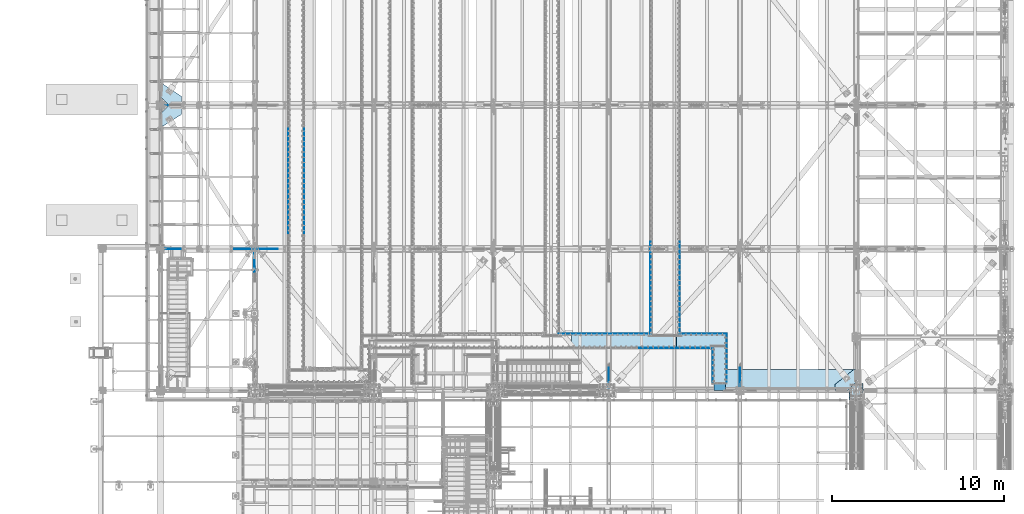
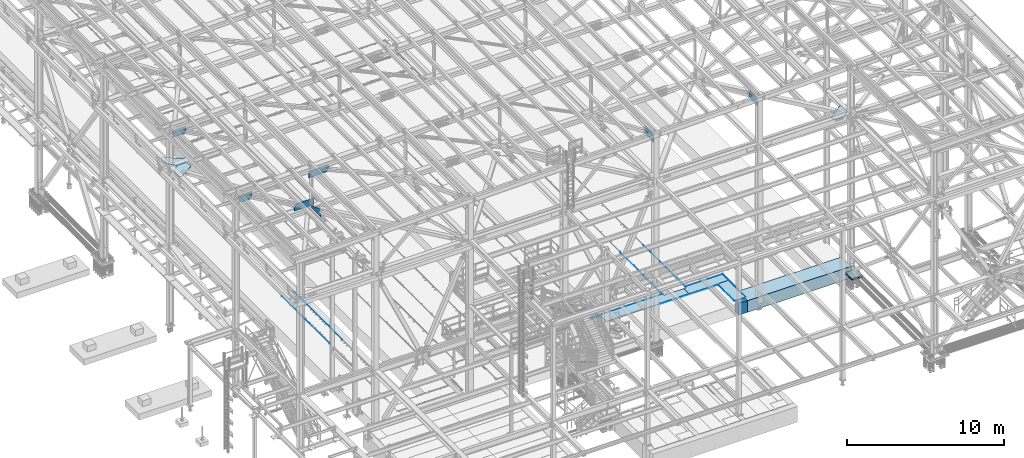
# One storey, part 2976 of 3843: 24 plates, 2 slabs, 24 elements without a shape of their own.
"""IFC2X3 building model written with IfcOpenShell, lengths in millimetres."""

from ifc_helpers import new_model, si_unit, frame, origin_with_axes, place, context, subcontext, project, spatial, faceted_brep, material, type_object, element, aggregate, save


model = new_model("IFC2X3")

# Units and contexts
model_context = context("Model", 3, precision=1e-05, world=origin_with_axes())
body_context = subcontext(model_context, "Body", "Model", "MODEL_VIEW")
ifc_project = project(units=[si_unit("LENGTHUNIT", "METRE", prefix="MILLI"), si_unit("AREAUNIT", "SQUARE_METRE"), si_unit("VOLUMEUNIT", "CUBIC_METRE"), si_unit("MASSUNIT", "GRAM", prefix="KILO"), si_unit("TIMEUNIT", "SECOND"), si_unit("PLANEANGLEUNIT", "RADIAN"), si_unit("SOLIDANGLEUNIT", "STERADIAN"), si_unit("THERMODYNAMICTEMPERATUREUNIT", "DEGREE_CELSIUS"), si_unit("LUMINOUSINTENSITYUNIT", "LUMEN")], contexts=[model_context])

# Site, building, storey
site_placement = place(None, origin_with_axes())
site = spatial("IfcSite", under=ifc_project, at=site_placement, CompositionType="ELEMENT")
building_placement = place(site_placement, origin_with_axes())
building = spatial("IfcBuilding", under=site, at=building_placement, Name="Undefined", CompositionType="ELEMENT")
storey_placement = place(building_placement, origin_with_axes())
storey = spatial("IfcBuildingStorey", under=building, at=storey_placement, Name="Undefined", CompositionType="ELEMENT", Elevation=0.0)

# Assembly, plate
assembly_1_placement = place(storey_placement, origin_with_axes())
assembly_1 = element("IfcElementAssembly", 1, at=assembly_1_placement, inside=storey, Name="EMBED_ANGLE", AssemblyPlace="NOTDEFINED", PredefinedType="RIGID_FRAME")
ifc_material_1 = material(Name="STEEL/A36")
plate_type_1 = type_object("IfcPlateType", PredefinedType="NOTDEFINED")
plate_1_placement = place(assembly_1_placement, frame((65069.2755560959, 28911.5502021554, 30480.0000003815), z_axis=(-1.0, 0.0, 0.0), x_axis=(0.0, 0.0, -1.0)))
plate_1 = element("IfcPlate", 2, at=plate_1_placement, type_object=plate_type_1, material=ifc_material_1, Name="PLATE", context=body_context, shape_type="Brep", body=[
    faceted_brep([(3.80565325031057e-07, -6.34999999414867, 5327.71371118224), (20.6374995432707, -6.34999999414867, 5327.71371118224), (25.3999996185303, -1.58765204696101, 5332.47605989833), (25.3999996185303, 6.3500000058666, 5340.41355616353), (3.81471181754023e-07, 6.3500000058666, 5340.41355616181), (25.3999996185303, -1.58750828453412, 7.93771022401779), (25.3999999999942, 6.34999999994034, 2.91038304567337e-11), (7.27595761418343e-12, 6.3499999046162, 0.0), (9.05856722965837e-10, -6.34999999998763, 12.7002012917728), (20.6374995432707, -6.34999999998763, 12.7002012917728)], [[[0, 1, 2, 3, 4]], [[3, 2, 5, 6]], [[4, 3, 6, 7]], [[0, 4, 7, 8]], [[1, 0, 8, 9]], [[2, 1, 9, 5]], [[8, 7, 6, 5, 9]]]),
])
aggregate(assembly_1, [plate_1])

assembly_2_placement = place(storey_placement, origin_with_axes())
assembly_2 = element("IfcElementAssembly", 3, at=assembly_2_placement, inside=storey, Name="EMBED_ANGLE", AssemblyPlace="NOTDEFINED", PredefinedType="RIGID_FRAME")
plate_2_placement = place(assembly_2_placement, frame((69501.5118787198, 28911.518202002, 30480.0), z_axis=(-0.999999999941156, 1.08469999968456e-05, -1.75999998152391e-07), x_axis=(0.0, 0.0, -1.0)))
plate_2 = element("IfcPlate", 4, at=plate_2_placement, type_object=plate_type_1, material=ifc_material_1, Name="PLATE", context=body_context, shape_type="Brep", body=[
    faceted_brep([(0.0, -6.34999999832871, 2743.20009635536), (20.6374992370511, -6.34999999832871, 2743.20009635536), (25.3999994290425, -1.58757329854052, 2747.96241314906), (25.3999992370591, 6.35000000169384, 2755.89995210941), (0.0, 6.35000000169384, 2755.89995210769), (25.3999996167695, 6.35000000001673, 12.718919349456), (0.0, 6.35000000001673, 12.718919349456), (0.0, -6.3499999046162, 0.0), (20.6375000381231, -6.35000000004948, 2.5465851649642e-11), (25.3999996182029, -1.61924383396763, 4.73780372471083)], [[[0, 1, 2, 3, 4]], [[4, 3, 5, 6]], [[0, 4, 6, 7]], [[1, 0, 7, 8]], [[2, 1, 8, 9]], [[3, 2, 9, 5]], [[8, 7, 6, 5, 9]]]),
])
aggregate(assembly_2, [plate_2])

assembly_3_placement = place(storey_placement, origin_with_axes())
assembly_3 = element("IfcElementAssembly", 5, at=assembly_3_placement, inside=storey, Name="EMBED_ANGLE", AssemblyPlace="NOTDEFINED", PredefinedType="RIGID_FRAME")
plate_3_placement = place(assembly_3_placement, frame((69495.1619228334, 26000.0750029394, 30480.0000003815), z_axis=(0.0, 1.0, 0.0), x_axis=(0.0, 0.0, -1.0)))
plate_3 = element("IfcPlate", 6, at=plate_3_placement, type_object=plate_type_1, material=ifc_material_1, Name="PLATE", context=body_context, shape_type="Brep", body=[
    faceted_brep([(20.6375000381231, -6.35000000004948, 2.5465851649642e-11), (0.0, -6.3499999046162, 0.0), (0.0, 6.34999999999854, 12.6999998092651), (25.3999996185303, 6.34999999999854, 12.6999999977998), (25.3999996185303, -1.58769240400579, 4.77717201472478), (25.3999996185303, -1.58766331075458, 2913.04279886661), (20.6374996185295, -6.34999999172578, 2917.8249962469), (3.81471181754023e-07, -6.34999999172578, 2917.82499624551), (3.79812263417989e-07, 6.3500000082422, 2905.12503064128), (25.3999996185303, 6.3500000082422, 2905.12503064128)], [[[0, 1, 2, 3, 4]], [[0, 4, 5, 6]], [[1, 0, 6, 7]], [[2, 1, 7, 8]], [[3, 2, 8, 9]], [[4, 3, 9, 5]], [[8, 7, 6, 5, 9]]]),
])
aggregate(assembly_3, [plate_3])

assembly_4_placement = place(storey_placement, origin_with_axes())
assembly_4 = element("IfcElementAssembly", 7, at=assembly_4_placement, inside=storey, Name="EMBED_ANGLE", AssemblyPlace="NOTDEFINED", PredefinedType="RIGID_FRAME")
plate_4_placement = place(assembly_4_placement, frame((68669.6619595486, 26000.0749946097, 30480.0000003815), z_axis=(0.0, 1.0, 0.0), x_axis=(0.0, 0.0, -1.0)))
plate_4 = element("IfcPlate", 8, at=plate_4_placement, type_object=plate_type_1, material=ifc_material_1, Name="PLATE", context=body_context, shape_type="Brep", body=[
    faceted_brep([(20.6374996185295, 6.34999999747379, 2079.6250003181), (3.79157427232713e-07, 6.34999999747379, 2079.6250003181), (3.81471181754023e-07, -6.35000000253785, 2092.32499955647), (25.3999996185303, -6.35000000253785, 2092.32499955819), (25.3999996185303, 1.5874999971129, 2084.38750129905), (25.3999996185303, -6.34999999999854, 12.7000000000044), (25.399999618523, 1.58750000001601, 4.76249999998981), (20.6374996185295, 6.35000000000218, -7.27595761418343e-12), (7.27595761418343e-12, 6.3499999046162, 0.0), (0.0, -6.34999999999854, 12.6999998092651)], [[[0, 1, 2, 3, 4]], [[4, 3, 5, 6]], [[0, 4, 6, 7]], [[1, 0, 7, 8]], [[2, 1, 8, 9]], [[3, 2, 9, 5]], [[8, 7, 6, 5, 9]]]),
])
aggregate(assembly_4, [plate_4])

assembly_5_placement = place(storey_placement, origin_with_axes())
assembly_5 = element("IfcElementAssembly", 9, at=assembly_5_placement, inside=storey, Name="EMBED_ANGLE", AssemblyPlace="NOTDEFINED", PredefinedType="RIGID_FRAME")
plate_5_placement = place(assembly_5_placement, frame((64415.1623417777, 28086.05, 30480.0000003815), z_axis=(1.0, 0.0, 0.0), x_axis=(0.0, 0.0, -1.0)))
plate_5 = element("IfcPlate", 10, at=plate_5_placement, type_object=plate_type_1, material=ifc_material_1, Name="PLATE", context=body_context, shape_type="Brep", body=[
    faceted_brep([(0.0, -6.3499999046162, 0.0), (7.27595761418343e-12, 6.3499999046162, 0.0), (25.3999999999942, 6.34999999994034, 2.91038304567337e-11), (25.3999996185921, -1.5874999999869, 7.27595761418343e-11), (20.6375000381231, -6.35000000004948, 2.5465851649642e-11), (25.3999995817285, 6.35000000567379, 4260.84946592642), (25.4000003800502, -1.58748479768838, 4252.91198546833), (20.6374996185295, -6.34999999434149, 4248.14946486166), (3.43643478117883e-07, -6.34999999434149, 4248.14946486166), (3.44669388141483e-07, 6.35000000567379, 4260.8494659247)], [[[0, 1, 2, 3, 4]], [[3, 2, 5, 6]], [[4, 3, 6, 7]], [[0, 4, 7, 8]], [[1, 0, 8, 9]], [[2, 1, 9, 5]], [[8, 7, 6, 5, 9]]]),
])
aggregate(assembly_5, [plate_5])

assembly_6_placement = place(storey_placement, origin_with_axes())
assembly_6 = element("IfcElementAssembly", 11, at=assembly_6_placement, inside=storey, Name="EMBED_ANGLE", AssemblyPlace="NOTDEFINED", PredefinedType="RIGID_FRAME")
plate_6_placement = place(assembly_6_placement, frame((66751.962, 34264.6001953125, 30479.9999992371), z_axis=(0.0, -1.0, 0.0), x_axis=(0.0, 0.0, -1.0)))
plate_6 = element("IfcPlate", 12, at=plate_6_placement, type_object=plate_type_1, material=ifc_material_1, Name="PLATE", context=body_context, shape_type="Brep", body=[
    faceted_brep([(25.3999996185303, -6.34999999999491, 2.91038304567337e-11), (0.0, -6.3499999046162, 0.0), (7.27595761418343e-12, 6.3499999046162, 0.0), (20.6374996185295, 6.35000000000218, -7.27595761418343e-12), (25.3999996185921, 1.58750000000146, 7.27595761418343e-11), (25.3999996185303, -6.35000000000582, 5359.40029227788), (3.81471181754023e-07, -6.35000000000582, 5359.40029227788), (3.80568963009864e-07, 6.35000000000582, 5346.70019531149), (20.6374984696922, 6.35000000000582, 5346.70019531149), (25.3999995800368, 1.58750000000873, 5351.46269531147)], [[[0, 1, 2, 3, 4]], [[1, 0, 5, 6]], [[2, 1, 6, 7]], [[3, 2, 7, 8]], [[4, 3, 8, 9]], [[0, 4, 9, 5]], [[8, 7, 6, 5, 9]]]),
])
aggregate(assembly_6, [plate_6])

assembly_7_placement = place(storey_placement, origin_with_axes())
assembly_7 = element("IfcElementAssembly", 13, at=assembly_7_placement, inside=storey, Name="EMBED_ANGLE", AssemblyPlace="NOTDEFINED", PredefinedType="RIGID_FRAME")
plate_7_placement = place(assembly_7_placement, frame((65062.9255556641, 34264.6002929687, 30479.9999992371), z_axis=(0.0, -1.0, 0.0), x_axis=(0.0, 0.0, -1.0)))
plate_7 = element("IfcPlate", 14, at=plate_7_placement, type_object=plate_type_1, material=ifc_material_1, Name="PLATE", context=body_context, shape_type="Brep", body=[
    faceted_brep([(0.0, -6.3499999046162, 0.0), (7.27595761418343e-12, 6.3499999046162, 0.0), (25.3999999999942, 6.34999999994034, 2.91038304567337e-11), (25.3999996185921, -1.5874999999869, 7.27595761418343e-11), (20.6375000381231, -6.35000000004948, 2.5465851649642e-11), (25.3999996185303, 6.34999999999854, 5359.40009081333), (25.3999996185303, -1.58750000000146, 5351.46279296873), (20.6374984696922, -6.34999999999854, 5346.70029296873), (3.80568963009864e-07, -6.34999999999854, 5346.70029296873), (3.81471181754023e-07, 6.34999999999854, 5359.40009081333)], [[[0, 1, 2, 3, 4]], [[3, 2, 5, 6]], [[4, 3, 6, 7]], [[0, 4, 7, 8]], [[1, 0, 8, 9]], [[2, 1, 9, 5]], [[8, 7, 6, 5, 9]]]),
])
aggregate(assembly_7, [plate_7])

assembly_8_placement = place(storey_placement, origin_with_axes())
assembly_8 = element("IfcElementAssembly", 15, at=assembly_8_placement, inside=storey, Name="PLATE", AssemblyPlace="NOTDEFINED", PredefinedType="RIGID_FRAME")
ifc_material_2 = material(Name="STEEL/A572-50")
plate_type_2 = type_object("IfcPlateType", PredefinedType="NOTDEFINED")
plate_8_placement = place(assembly_8_placement, frame((69482.4619438142, 28098.7500050658, 30467.3), z_axis=(-1.0, 0.0, 0.0), x_axis=(0.0, 1.0, 0.0)))
plate_8 = element("IfcPlate", 16, at=plate_8_placement, type_object=plate_type_2, material=ifc_material_2, Name="PLATE", context=body_context, shape_type="Brep", body=[
    faceted_brep([(704.849965960948, -12.7000000000007, 2911.47703445752), (704.84996764666, -12.7000000000007, 2742.90588481282), (704.84996764666, 12.7000000000007, 2742.90588481282), (704.849965960948, 12.7000000000007, 2911.47703445752), (800.073910520936, -12.7000000000007, 2742.90588576545), (800.073910520936, 12.7000000000007, 2742.90588576545), (-3.91444700653665e-06, -12.7000000000007, 2911.47701656907), (-3.91444700653665e-06, 12.7000000000007, 2911.47701656907), (-1.07959931483492e-06, 12.7000000000007, 802.981070808615), (-1.07959931483492e-06, -12.7000000000007, 802.981070808615), (85.724977552105, 12.7000000000007, 802.981070808499), (85.724977552105, -12.7000000000007, 802.981070808499), (85.724990093946, 12.7000000000007, 2.3283064365387e-10), (85.724990093946, -12.7000000000007, 2.3283064365387e-10), (800.094554221527, 12.7000000000007, 2.2846506908536e-09), (800.094554221527, -12.7000000000007, 2.2846506908536e-09)], [[[0, 1, 2, 3]], [[4, 5, 2, 1]], [[6, 7, 8, 9]], [[9, 8, 10, 11]], [[11, 10, 12, 13]], [[14, 15, 13, 12]], [[0, 6, 9, 11, 13, 15, 4, 1]], [[7, 6, 0, 3]], [[14, 12, 10, 8, 7, 3, 2, 5]], [[15, 14, 5, 4]]]),
])
aggregate(assembly_8, [plate_8])

assembly_9_placement = place(storey_placement, origin_with_axes())
assembly_9 = element("IfcElementAssembly", 17, at=assembly_9_placement, inside=storey, Name="PLATE", AssemblyPlace="NOTDEFINED", PredefinedType="RIGID_FRAME")
plate_9_placement = place(assembly_9_placement, frame((66567.8099273582, 28098.7500302273, 30467.3), z_axis=(-1.0, 0.0, 0.0), x_axis=(0.0, 1.0, 0.0)))
plate_9 = element("IfcPlate", 18, at=plate_9_placement, type_object=plate_type_2, material=ifc_material_2, Name="PLATE", context=body_context, shape_type="Brep", body=[
    faceted_brep([(704.849969829345, -12.7000000000007, 1.23691279441118e-09), (704.849969829345, 12.7000000000007, 1.23691279441118e-09), (704.850077272724, 12.7000000000007, 1492.1843209475), (704.850077272724, -12.7000000000007, 1492.1843209475), (800.116650633714, -12.7000000000007, 1492.18431408831), (800.116650633714, 12.7000000000007, 1492.18431408832), (0.0, -12.6999999999971, 0.0), (0.000493600375193637, -12.7000000000007, 6095.99999979503), (0.000493600375193637, 12.7000000000007, 6095.99999979503), (0.0, 12.6999999999971, 0.0), (800.116981974414, -12.7000000000007, 6096.00000000144), (800.116981974414, 12.7000000000007, 6096.00000000144)], [[[0, 1, 2, 3]], [[4, 3, 2, 5]], [[6, 7, 8, 9]], [[7, 10, 11, 8]], [[11, 10, 4, 5]], [[1, 9, 8, 11, 5, 2]], [[6, 9, 1, 0]], [[10, 7, 6, 0, 3, 4]]]),
])
aggregate(assembly_9, [plate_9])

assembly_10_placement = place(storey_placement, origin_with_axes())
assembly_10 = element("IfcElementAssembly", 19, at=assembly_10_placement, inside=storey, Name="PLATE", AssemblyPlace="NOTDEFINED", PredefinedType="RIGID_FRAME")
plate_10_placement = place(assembly_10_placement, frame((68682.3618078103, 28181.2999906114, 30467.3), z_axis=(1.0, 0.0, 0.0), x_axis=(0.0, -1.0, 0.0)))
plate_10 = element("IfcPlate", 20, at=plate_10_placement, type_object=plate_type_2, material=ifc_material_2, Name="PLATE", context=body_context, shape_type="Brep", body=[
    faceted_brep([(0.0, -12.6999999999971, 0.0), (5.08003176946659e-05, -12.7000000000007, 800.100116695074), (5.08003176946659e-05, 12.7000000000007, 800.100116695074), (0.0, 12.6999999999971, 0.0), (2162.26889035886, -12.7000000000007, 800.099943196918), (2162.26889035886, 12.7000000000007, 800.099943196918), (2162.17500086908, -12.7000000000007, -6.18456397205591e-09), (2162.17500086908, 12.7000000000007, -6.18456397205591e-09)], [[[0, 1, 2, 3]], [[1, 4, 5, 2]], [[4, 6, 7, 5]], [[6, 0, 3, 7]], [[5, 7, 3, 2]], [[6, 4, 1, 0]]]),
])
aggregate(assembly_10, [plate_10])

assembly_11_placement = place(storey_placement, origin_with_axes())
assembly_11 = element("IfcElementAssembly", 21, at=assembly_11_placement, inside=storey, Name="BEAM", AssemblyPlace="NOTDEFINED", PredefinedType="RIGID_FRAME")
plate_type_3 = type_object("IfcPlateType", PredefinedType="NOTDEFINED")
plate_11_placement = place(assembly_11_placement, frame((42265.3420523382, 33845.4999999999, 42433.4469214496), z_axis=(-0.00048281500021403, 0.0, 0.999999883444831), x_axis=(-0.999999883445314, 0.0, -0.000482814000210543)))
plate_11 = element("IfcPlate", 22, at=plate_11_placement, type_object=plate_type_3, material=ifc_material_2, Name="PLATE", context=body_context, shape_type="Brep", body=[
    faceted_brep([(0.0, -9.52500000000146, 0.0), (-1.35332811623812e-09, -9.52500000000146, 528.488950446263), (-1.35332811623812e-09, 9.52500000000146, 528.488950446263), (0.0, 9.52500000000146, 0.0), (1251.68139171164, -9.52500000000146, 529.093281072412), (1251.68139171164, 9.52500000000146, 529.093281072412), (1397.00000000605, -9.52500000000146, 261.165040183223), (1397.00000000605, 9.52500000000146, 261.165040183223), (1397.00000000671, -9.52500000000146, 3.5579432733357e-09), (1397.00000000671, 9.52500000000146, 3.5579432733357e-09)], [[[0, 1, 2, 3]], [[1, 4, 5, 2]], [[4, 6, 7, 5]], [[6, 8, 9, 7]], [[8, 0, 3, 9]], [[5, 7, 9, 3, 2]], [[8, 6, 4, 1, 0]]]),
])

assembly_12_placement = place(storey_placement, origin_with_axes())
assembly_12 = element("IfcElementAssembly", 23, at=assembly_12_placement, inside=storey, Name="EMBED_ANGLE", AssemblyPlace="NOTDEFINED", PredefinedType="RIGID_FRAME")
plate_type_4 = type_object("IfcPlateType", PredefinedType="NOTDEFINED")
plate_12_placement = place(assembly_12_placement, frame((44925.9959999999, 40846.3749999999, 30479.9999973298), z_axis=(0.0, -1.0, 0.0), x_axis=(0.0, 0.0, -1.0)))
plate_12 = element("IfcPlate", 24, at=plate_12_placement, type_object=plate_type_4, material=ifc_material_1, Name="PLATE", context=body_context, shape_type="Brep", body=[
    faceted_brep([(15.875, 1.58750000000146, 6096.0), (15.875, 1.58749999204883, -3.63797880709171e-12), (11.1125018504281, 6.35000000000582, -7.27595761418343e-12), (11.1124996186481, 6.34999999999854, 6096.0), (0.0, -6.3499999046162, 0.0), (3.81471181754023e-07, -6.34999999999854, 6096.0), (3.81471181754023e-07, 6.34999999999854, 6096.0), (7.27595761418343e-12, 6.3499999046162, 0.0), (15.875, -6.35000000000582, 3.63797880709171e-12), (15.875, -6.34999999999854, 6096.0)], [[[0, 1, 2, 3]], [[4, 5, 6, 7]], [[8, 9, 5, 4]], [[6, 5, 9, 0, 3]], [[7, 6, 3, 2]], [[8, 4, 7, 2, 1]], [[9, 8, 1, 0]]]),
])
aggregate(assembly_12, [plate_12])

assembly_13_placement = place(storey_placement, origin_with_axes())
assembly_13 = element("IfcElementAssembly", 25, at=assembly_13_placement, inside=storey, Name="EMBED_ANGLE", AssemblyPlace="NOTDEFINED", PredefinedType="RIGID_FRAME")
plate_13_placement = place(assembly_13_placement, frame((43998.896, 40846.3749999999, 30479.9999977112), z_axis=(0.0, -1.0, 0.0), x_axis=(0.0, 0.0, -1.0)))
plate_13 = element("IfcPlate", 26, at=plate_13_placement, type_object=plate_type_4, material=ifc_material_1, Name="PLATE", context=body_context, shape_type="Brep", body=[
    faceted_brep([(15.8749946755343, -1.58750000000146, 6096.0), (11.1124999999702, -6.34999999999854, 6096.0), (11.1125001907349, -6.35000000006371, 0.0), (15.875, -1.58750000024156, -3.63797880709171e-12), (0.0, -6.3499999046162, 0.0), (3.81471181754023e-07, -6.34999999999854, 6096.0), (3.81471181754023e-07, 6.34999999999854, 6096.0), (7.27595761418343e-12, 6.3499999046162, 0.0), (15.875, 6.34999999999854, 6096.0), (15.875, 6.34999999999854, -3.63797880709171e-12)], [[[0, 1, 2, 3]], [[4, 5, 6, 7]], [[8, 9, 7, 6]], [[9, 8, 0, 3]], [[4, 7, 9, 3, 2]], [[5, 4, 2, 1]], [[8, 6, 5, 1, 0]]]),
])
aggregate(assembly_13, [plate_13])

assembly_14_placement = place(storey_placement, origin_with_axes())
assembly_14 = element("IfcElementAssembly", 27, at=assembly_14_placement, inside=storey, Name="PLATE", AssemblyPlace="NOTDEFINED", PredefinedType="RIGID_FRAME")
plate_type_5 = type_object("IfcPlateType", PredefinedType="NOTDEFINED")
plate_14_placement = place(assembly_14_placement, frame((36582.3499999983, 41719.5, 42232.2630004883), z_axis=(1.0, 0.0, 0.0), x_axis=(0.0, -1.0, 0.0)))
plate_14 = element("IfcPlate", 28, at=plate_14_placement, type_object=plate_type_5, material=ifc_material_2, Name="PLATE", context=body_context, shape_type="Brep", body=[
    faceted_brep([(0.0, -14.2874999999985, 0.0), (-475.45624995463, -14.2874999999985, 476.25000003165), (-475.45624995463, 14.2874999999985, 476.25000003165), (0.0, 14.2874999999985, 0.0), (-475.45624994392, -14.2874999999985, 1212.85000003893), (-475.45624994392, 14.2874999999985, 1212.85000003893), (60.9233280424742, -14.2874999999985, 1212.85000000017), (60.9233280424742, 14.2874999999985, 1212.85000000017), (736.600000000006, -14.2874999999985, 149.225000001694), (736.600000000006, 14.2874999999985, 149.225000001694), (736.599999940488, -14.2874999999985, 0.0), (736.599999940488, 14.2874999999985, 0.0)], [[[0, 1, 2, 3]], [[1, 4, 5, 2]], [[4, 6, 7, 5]], [[6, 8, 9, 7]], [[8, 10, 11, 9]], [[10, 0, 3, 11]], [[5, 7, 9, 11, 3, 2]], [[10, 8, 6, 4, 1, 0]]]),
])
aggregate(assembly_14, [plate_14])

assembly_15_placement = place(storey_placement, origin_with_axes())
assembly_15 = element("IfcElementAssembly", 29, at=assembly_15_placement, inside=storey, Name="PLATE", AssemblyPlace="NOTDEFINED", PredefinedType="RIGID_FRAME")
plate_15_placement = place(assembly_15_placement, frame((37058.6, 42209.2437500015, 42232.2630004887), z_axis=(0.0, 1.0, 0.0), x_axis=(1.0, 0.0, 0.0)))
plate_15 = element("IfcPlate", 30, at=plate_15_placement, type_object=plate_type_5, material=ifc_material_2, Name="PLATE", context=body_context, shape_type="Brep", body=[
    faceted_brep([(0.0, -14.2874999999985, 0.0), (-476.249999993554, -14.2874999999985, 475.456250073548), (-476.249999993554, 14.2874999999985, 475.456250073548), (0.0, 14.2874999999985, 0.0), (-476.249999993568, -14.2874999999985, 1212.05625003844), (-476.249999993568, 14.2874999999985, 1212.05625003844), (-327.025000000001, -14.2874999999985, 1212.05624999852), (-327.025000000001, 14.2874999999985, 1212.05624999852), (736.599999997103, -14.2874999999985, 513.749258709016), (736.599999997103, 14.2874999999985, 513.749258709016), (736.599999940488, -14.2874999999985, 0.0), (736.599999940488, 14.2874999999985, 0.0)], [[[0, 1, 2, 3]], [[1, 4, 5, 2]], [[4, 6, 7, 5]], [[6, 8, 9, 7]], [[8, 10, 11, 9]], [[10, 0, 3, 11]], [[5, 7, 9, 11, 3, 2]], [[10, 8, 6, 4, 1, 0]]]),
])
aggregate(assembly_15, [plate_15])

assembly_16_placement = place(storey_placement, origin_with_axes())
assembly_16 = element("IfcElementAssembly", 31, at=assembly_16_placement, inside=storey, Name="PLATE", AssemblyPlace="NOTDEFINED", PredefinedType="RIGID_FRAME")
plate_16_placement = place(assembly_16_placement, frame((77008.0374999847, 26098.5000000001, 42232.2630004883), z_axis=(-1.0, 0.0, 0.0), x_axis=(0.0, 1.0, 0.0)))
plate_16 = element("IfcPlate", 32, at=plate_16_placement, type_object=plate_type_5, material=ifc_material_2, Name="PLATE", context=body_context, shape_type="Brep", body=[
    faceted_brep([(0.0, -14.2874999999985, 0.0), (-476.250000048109, -14.2874999999985, 477.83749997773), (-476.250000048109, 14.2874999999985, 477.83749997773), (0.0, 14.2874999999985, 0.0), (-476.250000048109, -14.2874999999985, 1214.43749997662), (-476.250000048109, 14.2874999999985, 1214.43749997662), (-116.181480294774, -14.2874999999985, 1214.4374999766), (-116.181480294774, 14.2874999999985, 1214.4374999766), (736.600000090519, -14.2874999999985, 147.637499993114), (736.600000090519, 14.2874999999985, 147.637499993114), (736.599999940488, -14.2874999999985, 0.0), (736.599999940488, 14.2874999999985, 0.0)], [[[0, 1, 2, 3]], [[1, 4, 5, 2]], [[4, 6, 7, 5]], [[6, 8, 9, 7]], [[8, 10, 11, 9]], [[10, 0, 3, 11]], [[5, 7, 9, 11, 3, 2]], [[10, 8, 6, 4, 1, 0]]]),
])
aggregate(assembly_16, [plate_16])

# Plate
plate_type_6 = type_object("IfcPlateType", PredefinedType="NOTDEFINED")
plate_17_placement = place(assembly_11_placement, frame((42038.5875000002, 32495.5135896303, 42405.9268950663), z_axis=(0.0, -0.000321877000067616, 0.999999948197597), x_axis=(0.0, 0.999999948197597, 0.000321877000061539)))
plate_17 = element("IfcPlate", 33, at=plate_17_placement, type_object=plate_type_6, material=ifc_material_2, context=body_context, shape_type="Brep", body=[
    faceted_brep([(0.0, -7.9375, 0.0), (2.18278728425503e-11, -7.9375, 73.9483431657936), (2.18278728425503e-11, 7.9375, 73.9483431657936), (0.0, 7.9375, 0.0), (178.772091322528, -7.9375, 549.452853513401), (178.772091322528, 7.9375, 549.452853513401), (1136.46773030707, -7.9375, 177.799999998424), (1136.46773030707, 7.9375, 177.799999998424), (1136.46773030702, -7.9375, -2.83762346953154e-10), (1136.46773030702, 7.9375, -2.83762346953154e-10)], [[[0, 1, 2, 3]], [[1, 4, 5, 2]], [[4, 6, 7, 5]], [[6, 8, 9, 7]], [[8, 0, 3, 9]], [[5, 7, 9, 3, 2]], [[8, 6, 4, 1, 0]]]),
])

aggregate(assembly_11, [plate_11, plate_17])

# Assembly, plate
assembly_17_placement = place(storey_placement, origin_with_axes())
assembly_17 = element("IfcElementAssembly", 34, at=assembly_17_placement, inside=storey, Name="BEAM", AssemblyPlace="NOTDEFINED", PredefinedType="RIGID_FRAME")
plate_type_7 = type_object("IfcPlateType", PredefinedType="NOTDEFINED")
plate_18_placement = place(assembly_17_placement, frame((36772.8500000198, 33845.5, 45028.8425329179), z_axis=(1.0, 0.0, 0.0), x_axis=(0.0, 0.0, -1.0)))
plate_18 = element("IfcPlate", 35, at=plate_18_placement, type_object=plate_type_7, material=ifc_material_2, Name="PLATE", context=body_context, shape_type="Brep", body=[
    faceted_brep([(1.0415270375961, -9.52500000000146, 979.158504298284), (-18.0040135895688, 9.52500000000146, 978.746371852198), (3.17538710204826, 9.52500000000146, 0.0), (22.2298459928788, -9.52500000000146, 0.0), (274.347507502687, -9.52500000000146, 985.072658402103), (274.347507502687, 9.52500000000146, 985.072658402103), (520.012681549633, -9.52500000000146, 851.982529440364), (520.012681549633, 9.52500000000146, 851.982529440364), (520.012681549633, -9.52500000000146, 0.0), (520.012681549633, 9.52500000000146, 0.0)], [[[0, 1, 2, 3]], [[4, 5, 1, 0]], [[4, 6, 7, 5]], [[6, 8, 9, 7]], [[9, 8, 3, 2]], [[5, 7, 9, 2, 1]], [[8, 6, 4, 0, 3]]]),
])

assembly_18_placement = place(storey_placement, origin_with_axes())
assembly_18 = element("IfcElementAssembly", 36, at=assembly_18_placement, inside=storey, Name="BEAM", AssemblyPlace="NOTDEFINED", PredefinedType="RIGID_FRAME")
plate_type_8 = type_object("IfcPlateType", PredefinedType="NOTDEFINED")
plate_19_placement = place(assembly_18_placement, frame((36772.8499999893, 42202.1, 45030.1542954677), z_axis=(1.0, 0.0, 0.0), x_axis=(0.0, 0.0, -1.0)))
plate_19 = element("IfcPlate", 37, at=plate_19_placement, type_object=plate_type_8, material=ifc_material_2, Name="PLATE", context=body_context, shape_type="Brep", body=[
    faceted_brep([(22.2326984329993, 9.52500000000146, 0.0), (3.17609494728822, -9.52499999999418, 0.0), (-22.2467702547365, -9.52500000000146, 964.427693481834), (-3.20338629249454, 9.52500000000146, 964.929687703894), (293.085216323067, -9.52500000000146, 972.740020514007), (293.085216323067, 9.52500000000146, 972.740020514007), (516.815926009396, -9.52500000000146, 852.487909349147), (516.815926009396, 9.52500000000146, 852.487909349147), (516.815926009396, -9.52500000000146, 0.0), (516.815926009396, 9.52500000000146, 0.0)], [[[0, 1, 2, 3]], [[4, 5, 3, 2]], [[4, 6, 7, 5]], [[6, 8, 9, 7]], [[9, 8, 1, 0]], [[5, 7, 9, 0, 3]], [[8, 6, 4, 2, 1]]]),
])
aggregate(assembly_18, [plate_19])

# Plate
plate_type_9 = type_object("IfcPlateType", PredefinedType="NOTDEFINED")
plate_20_placement = place(assembly_17_placement, frame((43373.6092947943, 33845.5, 45171.6784401758), z_axis=(0.0216342480057937, 0.0, -0.999765952267441), x_axis=(-0.999765952267441, 0.0, -0.0216342480057875)))
plate_20 = element("IfcPlate", 38, at=plate_20_placement, type_object=plate_type_9, material=ifc_material_2, Name="PLATE", context=body_context, shape_type="Brep", body=[
    faceted_brep([(0.0, -9.52500000000146, 0.0), (-3.71073838323355e-10, -9.52500000000146, 279.063821091899), (-3.71073838323355e-10, 9.52500000000146, 279.063821091899), (0.0, 9.52500000000146, 0.0), (108.316607885048, -9.52500000000146, 508.81044962156), (108.316607885048, 9.52500000000146, 508.81044962156), (1449.55630085266, -9.52500000000146, 508.810449623241), (1449.55630085266, 9.52500000000146, 508.810449623241), (1438.54599246055, -9.52500000000146, 1.81898940354586e-09), (1438.54599246055, 9.52500000000146, 1.81898940354586e-09)], [[[0, 1, 2, 3]], [[1, 4, 5, 2]], [[4, 6, 7, 5]], [[6, 8, 9, 7]], [[8, 0, 3, 9]], [[5, 7, 9, 3, 2]], [[8, 6, 4, 1, 0]]]),
])

aggregate(assembly_17, [plate_18, plate_20])

# Assembly, plate
assembly_19_placement = place(storey_placement, origin_with_axes())
assembly_19 = element("IfcElementAssembly", 39, at=assembly_19_placement, inside=storey, Name="PLATE", AssemblyPlace="NOTDEFINED", PredefinedType="RIGID_FRAME")
plate_type_10 = type_object("IfcPlateType", PredefinedType="NOTDEFINED")
plate_21_placement = place(assembly_19_placement, frame((62636.4, 25793.6999999751, 45618.7206121421), z_axis=(0.0, 1.0, 0.0), x_axis=(0.0, 0.0, -1.0)))
plate_21 = element("IfcPlate", 40, at=plate_21_placement, type_object=plate_type_10, material=ifc_material_2, Name="PLATE", context=body_context, shape_type="Brep", body=[
    faceted_brep([(0.0, -7.9375, 0.0), (-8.38190317153931e-09, -7.9375, 1152.13672545713), (-8.38190317153931e-09, 7.9375, 1152.13672545713), (0.0, 7.9375, 0.0), (168.287947070909, -7.9375, 1152.13672545836), (168.287947070909, 7.9375, 1152.13672545836), (576.860416930474, -7.9375, 977.068776156226), (576.860416930474, 7.9375, 977.068776156226), (576.860416930474, -7.9375, 0.0), (576.860416930474, 7.9375, 0.0)], [[[0, 1, 2, 3]], [[1, 4, 5, 2]], [[4, 6, 7, 5]], [[6, 8, 9, 7]], [[8, 0, 3, 9]], [[5, 7, 9, 3, 2]], [[8, 6, 4, 1, 0]]]),
])
aggregate(assembly_19, [plate_21])

assembly_20_placement = place(storey_placement, origin_with_axes())
assembly_20 = element("IfcElementAssembly", 41, at=assembly_20_placement, inside=storey, Name="PLATE", AssemblyPlace="NOTDEFINED", PredefinedType="RIGID_FRAME")
plate_type_11 = type_object("IfcPlateType", PredefinedType="NOTDEFINED")
plate_22_placement = place(assembly_20_placement, frame((70256.4, 25793.7000000153, 45783.6121849565), z_axis=(0.0, 1.0, 0.0), x_axis=(0.0, 0.0, -1.0)))
plate_22 = element("IfcPlate", 42, at=plate_22_placement, type_object=plate_type_11, material=ifc_material_2, Name="PLATE", context=body_context, shape_type="Brep", body=[
    faceted_brep([(0.0, -7.9375, 0.0), (0.0, -7.9375, 1134.17812790165), (0.0, 7.9375, 1134.17812790165), (0.0, 7.9375, 0.0), (184.59603992154, -7.9375, 1134.17812790165), (184.59603992154, 7.9375, 1134.17812790165), (590.236653302934, -7.9375, 952.420204345173), (590.236653302934, 7.9375, 952.420204345173), (590.236653302934, -7.9375, -3.63797880709171e-12), (590.236653302934, 7.9375, -3.63797880709171e-12)], [[[0, 1, 2, 3]], [[1, 4, 5, 2]], [[4, 6, 7, 5]], [[6, 8, 9, 7]], [[8, 0, 3, 9]], [[5, 7, 9, 3, 2]], [[8, 6, 4, 1, 0]]]),
])
aggregate(assembly_20, [plate_22])

# Assembly, slab
assembly_21_placement = place(storey_placement, origin_with_axes())
assembly_21 = element("IfcElementAssembly", 43, at=assembly_21_placement, inside=storey, Name="SLAB", AssemblyPlace="NOTDEFINED", PredefinedType="REINFORCEMENT_UNIT")
ifc_material_3 = material(Name="CONCRETE/3000")
slab_type_1 = type_object("IfcSlabType", PredefinedType="NOTDEFINED")
slab_1_placement = place(assembly_21_placement, frame((69412.6119223935, 26088.9750039666, 30022.8), z_axis=(0.0, -1.0, 0.0), x_axis=(-1.0, 0.0, 0.0)))
slab_1 = element("IfcSlab", 44, at=slab_1_placement, type_object=slab_type_1, material=ifc_material_3, Name="SLAB", PredefinedType="FLOOR", context=body_context, shape_type="Brep", body=[
    faceted_brep([(660.39996337927, -431.799540953492, 76.199994696155), (2.61934474110603e-10, -431.799540292799, 76.199986107782), (0.0, -431.800000000287, 0.0), (660.399963378906, -431.800000134539, -6.3664629124105e-10), (660.39996337927, -457.20000014425, 76.1999946929136), (0.0, -457.200000000001, 76.2000000000262), (660.399963381089, 457.200000000001, 473.075012206387), (660.399963378906, 457.200000000001, -6.3664629124105e-10), (0.0, 457.200000000001, 0.0), (1.55705492943525e-09, 457.200000000001, 473.074951171871), (1.55705492943525e-09, -457.200000000001, 473.074951171871), (660.399963381089, -457.200000000001, 473.075012206387)], [[[0, 1, 2, 3]], [[4, 5, 1, 0]], [[6, 7, 8, 9]], [[10, 11, 6, 9]], [[3, 7, 6, 11, 4, 0]], [[8, 7, 3, 2]], [[10, 9, 8, 2, 1, 5]], [[11, 10, 5, 4]]]),
])
aggregate(assembly_21, [slab_1])

assembly_22_placement = place(storey_placement, origin_with_axes())
assembly_22 = element("IfcElementAssembly", 45, at=assembly_22_placement, inside=storey, Name="SLAB", AssemblyPlace="NOTDEFINED", PredefinedType="REINFORCEMENT_UNIT")
slab_type_2 = type_object("IfcSlabType", PredefinedType="NOTDEFINED")
slab_2_placement = place(assembly_22_placement, frame((77012.79990625, 26825.575, 30022.8), z_axis=(0.0, -1.0, 0.0), x_axis=(-1.0, 0.0, 0.0)))
slab_2 = element("IfcSlab", 46, at=slab_2_placement, type_object=slab_type_2, material=ifc_material_3, Name="SLAB", PredefinedType="FLOOR", context=body_context, shape_type="Brep", body=[
    faceted_brep([(7523.96413888907, -457.200000000001, -7.89441401138902e-09), (7523.96413888969, -431.813993094667, -7.89441401138902e-09), (7523.96415189664, -431.800000762531, 812.893356999852), (7523.96415189604, -457.200000373068, 812.893794210009), (7600.16415189664, -431.799999999999, 812.893355780867), (7600.18798828124, -431.813992332118, -7.97444954514503e-09), (7600.14032368765, -457.200000375844, 812.893792991417), (0.0, -457.200000000001, 0.0), (-8.59550782479346e-05, -457.200000000001, 1209.67504882812), (-8.59550782479346e-05, 457.200000000001, 1209.67504882812), (0.0, 457.200000000001, 0.0), (7600.18798828682, 457.200000000001, 1209.67492675042), (7600.18798828124, 457.200000000001, -7.97444954514503e-09), (7600.18798828682, -457.200000000001, 1209.67492675042)], [[[0, 1, 2, 3]], [[4, 2, 1, 5]], [[6, 3, 2, 4]], [[7, 8, 9, 10]], [[11, 12, 10, 9]], [[8, 13, 11, 9]], [[5, 12, 11, 13, 6, 4]], [[0, 7, 10, 12, 5, 1]], [[13, 8, 7, 0, 3, 6]]]),
])
aggregate(assembly_22, [slab_2])

# Assembly, plate
assembly_23_placement = place(storey_placement, origin_with_axes())
assembly_23 = element("IfcElementAssembly", 47, at=assembly_23_placement, inside=storey, Name="COLUMN", AssemblyPlace="NOTDEFINED", PredefinedType="RIGID_FRAME")
plate_type_12 = type_object("IfcPlateType", PredefinedType="NOTDEFINED")
plate_23_placement = place(assembly_23_placement, frame((76631.8, 24803.1, 30099.0), z_axis=(0.0, 1.0, 0.0), x_axis=(1.0, 0.0, 0.0)))
plate_23 = element("IfcPlate", 48, at=plate_23_placement, type_object=plate_type_12, material=ifc_material_2, Name="PLATE", context=body_context, shape_type="Brep", body=[
    faceted_brep([(0.0, -38.0999999999985, 0.0), (0.0, -38.0999999999985, 1219.19995117188), (0.0, 38.0999999999985, 1219.19995117188), (0.0, 38.0999999999985, 0.0), (762.0, -38.0999999999985, 1219.19995117188), (762.0, 38.0999999999985, 1219.19995117188), (762.0, -38.0999999999985, 0.0), (762.0, 38.0999999999985, 0.0)], [[[0, 1, 2, 3]], [[1, 4, 5, 2]], [[4, 6, 7, 5]], [[6, 0, 3, 7]], [[5, 7, 3, 2]], [[6, 4, 1, 0]]]),
])
aggregate(assembly_23, [plate_23])

assembly_24_placement = place(storey_placement, origin_with_axes())
assembly_24 = element("IfcElementAssembly", 49, at=assembly_24_placement, inside=storey, Name="GROUT", AssemblyPlace="NOTDEFINED", PredefinedType="REINFORCEMENT_UNIT")
ifc_material_4 = material(Name="CONCRETE/Concrete_Undefined")
plate_type_13 = type_object("IfcPlateType", PredefinedType="NOTDEFINED")
plate_24_placement = place(assembly_24_placement, frame((76593.7, 24765.0, 30041.85), z_axis=(0.0, 1.0, 0.0), x_axis=(1.0, 0.0, 0.0)))
plate_24 = element("IfcPlate", 50, at=plate_24_placement, type_object=plate_type_13, material=ifc_material_4, Name="GROUT", context=body_context, shape_type="Brep", body=[
    faceted_brep([(38.1000000006898, -19.0499999997955, 1257.29999999931), (0.0, 19.0499999999993, 1295.40002441406), (0.0, 19.0500000000029, 0.0), (38.1000000006916, -19.0499999999811, 38.1000000006607), (800.099999999336, -19.0499999998101, 38.1000000006607), (838.200012207031, 19.0499999999993, 0.0), (838.200012207031, 19.0499999999993, 1295.40002441406), (800.099999999336, -19.0499999999956, 1257.29999999931)], [[[0, 1, 2, 3]], [[4, 5, 6, 7]], [[4, 7, 0, 3]], [[5, 4, 3, 2]], [[6, 5, 2, 1]], [[7, 6, 1, 0]]]),
])
aggregate(assembly_24, [plate_24])

save(model, "model.ifc")
